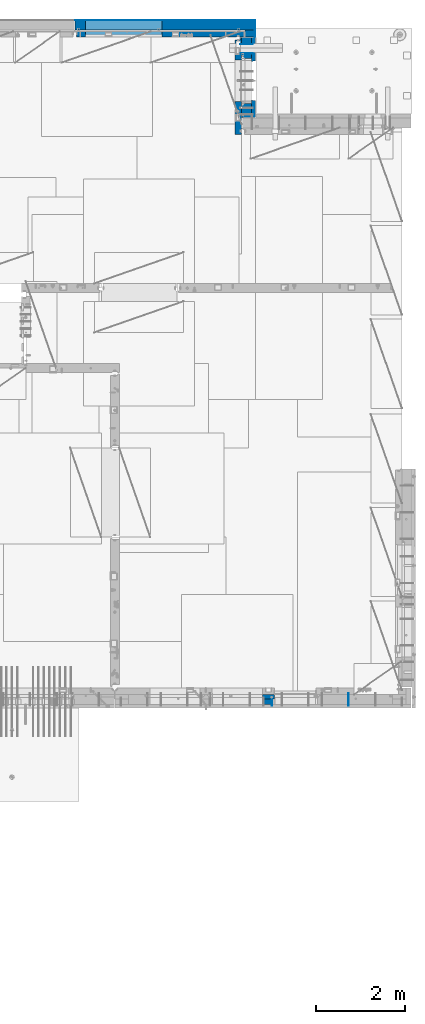
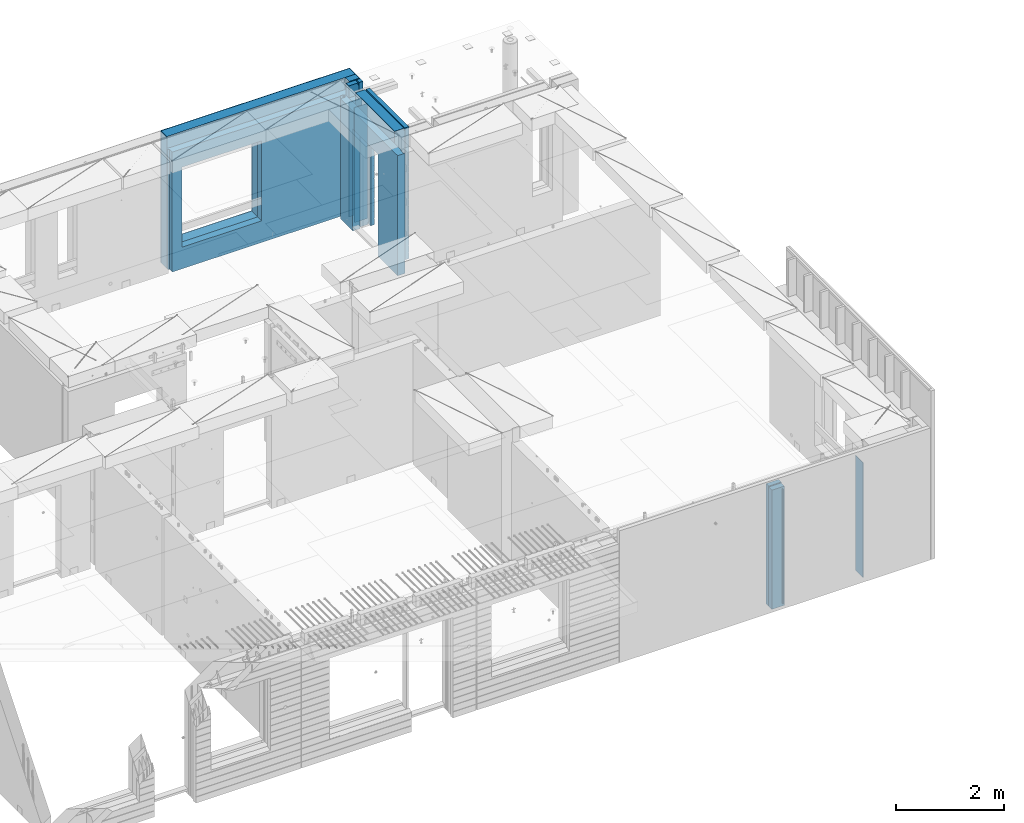
# One storey, part 205 of 309: 14 walls, 3 elements without a shape of their own.
"""IFC2X3 building model written with IfcOpenShell, lengths in millimetres."""

from ifc_helpers import new_model, si_unit, frame, origin_with_axes, place, context, subcontext, project, spatial, faceted_brep, material, type_object, element, aggregate, save


model = new_model("IFC2X3")

# Units and contexts
model_context = context("Model", 3, precision=1e-05, world=origin_with_axes())
body_context = subcontext(model_context, "Body", "Model", "MODEL_VIEW")
ifc_project = project(units=[si_unit("LENGTHUNIT", "METRE", prefix="MILLI"), si_unit("AREAUNIT", "SQUARE_METRE"), si_unit("VOLUMEUNIT", "CUBIC_METRE"), si_unit("MASSUNIT", "GRAM", prefix="KILO"), si_unit("TIMEUNIT", "SECOND"), si_unit("PLANEANGLEUNIT", "RADIAN"), si_unit("SOLIDANGLEUNIT", "STERADIAN"), si_unit("THERMODYNAMICTEMPERATUREUNIT", "DEGREE_CELSIUS"), si_unit("LUMINOUSINTENSITYUNIT", "LUMEN")], contexts=[model_context])

# Site, building, storey
site_placement = place(None, origin_with_axes())
site = spatial("IfcSite", under=ifc_project, at=site_placement, CompositionType="ELEMENT")
building_placement = place(site_placement, origin_with_axes())
building = spatial("IfcBuilding", under=site, at=building_placement, CompositionType="ELEMENT")
storey_placement = place(building_placement, origin_with_axes())
storey = spatial("IfcBuildingStorey", under=building, at=storey_placement, Name="7", CompositionType="ELEMENT", Elevation=0.0)

# Assembly, walls
assembly_1_placement = place(storey_placement, origin_with_axes())
assembly_1 = element("IfcElementAssembly", 1, at=assembly_1_placement, inside=storey, AssemblyPlace="NOTDEFINED", PredefinedType="REINFORCEMENT_UNIT")
ifc_material_1 = material(Name="Undefined")
wall_type_1 = type_object("IfcWallType", PredefinedType="NOTDEFINED")
wall_1_placement = place(assembly_1_placement, frame((33860.0, 7880.0, 101115.0), z_axis=(0.0, 0.0, 1.0), x_axis=(0.0, -1.0, 0.0)))
wall_1 = element("IfcWall", 2, at=wall_1_placement, type_object=wall_type_1, material=ifc_material_1, Name="(PD)", context=body_context, shape_type="Brep", body=[
    faceted_brep([(0.0, 5.0, -1300.0), (0.0, 5.0, 1300.0), (280.0, 5.0, 1300.0), (280.0, 5.0, -1300.0), (0.0, -5.0, 1300.0), (280.0, -5.0, 1300.0), (0.0, -5.0, -1300.0), (280.0, -5.0, -1300.0)], [[[0, 1, 2, 3]], [[1, 4, 5, 2]], [[4, 6, 7, 5]], [[6, 0, 3, 7]], [[5, 7, 3, 2]], [[6, 4, 1, 0]]]),
])
wall_2_placement = place(assembly_1_placement, frame((32144.9998946285, 7780.0, 101115.0), z_axis=(0.0, 0.0, 1.0), x_axis=(0.0, -1.0, 0.0)))
wall_2 = element("IfcWall", 3, at=wall_2_placement, type_object=wall_type_1, material=ifc_material_1, Name="(PD)", context=body_context, shape_type="Brep", body=[
    faceted_brep([(0.0, 5.0, -1300.0), (0.0, 5.0, 1300.0), (180.0, 5.0, 1300.0), (180.0, 5.0, -1300.0), (0.0, -5.0, 1300.0), (180.0, -5.0, 1300.0), (0.0, -5.0, -1300.0), (180.0, -5.0, -1300.0)], [[[0, 1, 2, 3]], [[1, 4, 5, 2]], [[4, 6, 7, 5]], [[6, 0, 3, 7]], [[5, 7, 3, 2]], [[6, 4, 1, 0]]]),
])

assembly_2_placement = place(storey_placement, origin_with_axes())
assembly_2 = element("IfcElementAssembly", 4, at=assembly_2_placement, inside=storey, AssemblyPlace="NOTDEFINED", PredefinedType="REINFORCEMENT_UNIT")
wall_3_placement = place(assembly_2_placement, frame((31429.9951872276, 22245.0, 101115.0), z_axis=(0.0, 0.0, 1.0), x_axis=(1.0, 0.0, 0.0)))
wall_3 = element("IfcWall", 5, at=wall_3_placement, type_object=wall_type_1, material=ifc_material_1, Name="(PD)", context=body_context, shape_type="Brep", body=[
    faceted_brep([(0.0, 5.0, -1300.0), (0.0, 5.0, 1300.0), (280.0, 5.0, 1300.0), (280.0, 5.0, -1300.0), (0.0, -5.0, 1300.0), (280.0, -5.0, 1300.0), (0.0, -5.0, -1300.0), (280.0, -5.0, -1300.0)], [[[0, 1, 2, 3]], [[1, 4, 5, 2]], [[4, 6, 7, 5]], [[6, 0, 3, 7]], [[5, 7, 3, 2]], [[6, 4, 1, 0]]]),
])
wall_4_placement = place(assembly_2_placement, frame((31429.9951872276, 22454.9997558594, 101115.0), z_axis=(0.0, 0.0, 1.0), x_axis=(1.0, 0.0, 0.0)))
wall_4 = element("IfcWall", 6, at=wall_4_placement, type_object=wall_type_1, material=ifc_material_1, Name="(PD)", context=body_context, shape_type="Brep", body=[
    faceted_brep([(0.0, 5.0, -1300.0), (0.0, 5.0, 1300.0), (280.0, 5.0, 1300.0), (280.0, 5.0, -1300.0), (0.0, -5.0, 1300.0), (280.0, -5.0, 1300.0), (0.0, -5.0, -1300.0), (280.0, -5.0, -1300.0)], [[[0, 1, 2, 3]], [[1, 4, 5, 2]], [[4, 6, 7, 5]], [[6, 0, 3, 7]], [[5, 7, 3, 2]], [[6, 4, 1, 0]]]),
])
ifc_material_2 = material(Name="COS5gt")
wall_type_2 = type_object("IfcWallType", PredefinedType="NOTDEFINED")
wall_5_placement = place(assembly_2_placement, frame((31569.9951872276, 22605.0, 101247.5), z_axis=(0.0, 0.0, 1.0), x_axis=(0.0, -1.0, 0.0)))
wall_5 = element("IfcWall", 7, at=wall_5_placement, type_object=wall_type_2, material=ifc_material_2, context=body_context, shape_type="Brep", body=[
    faceted_brep([(355.0, 110.0, 1442.5), (355.0, 109.999999999996, 1222.5), (355.0, -110.0, 1222.5), (355.0, -110.0, 1492.5), (355.0, 90.0, 1492.5), (355.0, 90.0, 1442.5), (255.0, 110.0, 1222.5), (255.0, -110.0, 1222.5), (0.0, 90.0, 1442.5), (0.0, 90.0, 1492.5), (105.0, 90.0, 1492.5), (105.0, 90.0, 1442.5), (0.0, 110.0, 1442.5), (105.0, 110.0, 1442.5), (1800.0, 90.0, -1442.5), (1800.0, 90.0, -1492.5), (1475.00010981862, 90.0, -1492.5), (1475.00010981862, 90.0, -1442.5), (1800.0, 110.0, -1442.5), (1475.00010981862, 110.0, -1442.5), (1800.0, 110.0, 1442.5), (1800.0, 90.0, 1442.5), (1800.0, 90.0, 1492.5), (1800.0, -110.0, 1492.5), (1800.0, -110.0, -1492.5), (1475.00010981862, -110.0, -1492.5), (1475.00010981862, -110.000000000004, 857.5), (1475.00010981862, 110.0, 857.5), (465.000109818619, -110.000000000004, 857.5), (465.000109818619, 110.0, 857.5), (0.0, -110.0, -1492.5), (0.0, 90.0, -1492.5), (465.000109818619, 90.0, -1492.5), (465.000109818619, -110.0, -1492.5), (0.0, 90.0, -1442.5), (465.000109818619, 90.0, -1442.5), (465.000109818619, 110.0, -1442.5), (0.0, 110.0, -1442.5), (0.0, -110.0, 1492.5), (105.0, -110.0, 1492.5), (105.0, -110.0, 1222.5), (105.0, 110.0, 1222.5), (205.0, 110.0, 1222.5), (205.0, -110.0, 1222.5)], [[[0, 1, 2, 3, 4, 5]], [[6, 7, 2, 1]], [[8, 9, 10, 11]], [[12, 8, 11, 13]], [[14, 15, 16, 17]], [[18, 14, 17, 19]], [[20, 21, 22, 23, 24, 15, 14, 18]], [[15, 24, 25, 16]], [[19, 17, 16, 25, 26, 27]], [[27, 26, 28, 29]], [[30, 31, 32, 33]], [[31, 34, 35, 32]], [[29, 28, 33, 32, 35, 36]], [[34, 37, 36, 35]], [[31, 30, 38, 9, 8, 12, 37, 34]], [[9, 38, 39, 10]], [[13, 11, 10, 39, 40, 41]], [[0, 20, 18, 19, 27, 29, 36, 37, 12, 13, 41, 42, 6, 1]], [[21, 20, 0, 5]], [[22, 21, 5, 4]], [[23, 22, 4, 3]], [[43, 40, 39, 38, 30, 33, 28, 26, 25, 24, 23, 3, 2, 7]], [[42, 41, 40, 43, 7, 6]]]),
])

assembly_3_placement = place(storey_placement, origin_with_axes())
assembly_3 = element("IfcElementAssembly", 8, at=assembly_3_placement, inside=storey, AssemblyPlace="NOTDEFINED", PredefinedType="REINFORCEMENT_UNIT")
ifc_material_3 = material()
wall_6_placement = place(assembly_3_placement, frame((31645.0, 22620.0, 101247.5), z_axis=(0.0, 0.0, 1.0), x_axis=(0.0, 1.0, 0.0)))
wall_6 = element("IfcWall", 9, at=wall_6_placement, type_object=wall_type_2, material=ifc_material_3, context=body_context, shape_type="Brep", body=[
    faceted_brep([(0.0, 110.0, -1492.5), (0.0, 110.0, 1492.5), (150.0, 110.0, 1492.5), (150.0, 110.0, -1492.5), (0.0, -110.0, 1492.5), (150.0, -110.0, 1492.5), (0.0, -110.0, -1492.5), (150.0, -110.0, -1492.5)], [[[0, 1, 2, 3]], [[1, 4, 5, 2]], [[4, 6, 7, 5]], [[6, 0, 3, 7]], [[5, 7, 3, 2]], [[6, 4, 1, 0]]]),
])
wall_7_placement = place(assembly_3_placement, frame((27720.0, 22880.0, 101247.5), z_axis=(0.0, 0.0, 1.0), x_axis=(1.0, 0.0, 0.0)))
wall_7 = element("IfcWall", 10, at=wall_7_placement, type_object=wall_type_2, material=ifc_material_3, context=body_context, shape_type="Brep", body=[
    faceted_brep([(0.0, -110.0, -1492.5), (0.0, 110.0, -1492.5), (4035.0, 110.0, -1492.5), (4035.0, -110.0, -1492.5), (0.0, -110.0, 1492.5), (0.0, 110.0, 1492.5), (4035.0, -110.0, 1492.5), (4035.0, 110.0, 1492.5), (234.997879677034, 110.0, -1002.5), (1944.99787967703, 110.0, -1002.5), (1944.99787967703, 110.0, 807.5), (234.997879677034, 110.0, 807.5), (234.997879677034, -110.0, -1002.5), (234.997879677034, -110.0, 807.5), (1944.99787967703, -110.0, 807.5), (1944.99787967703, -110.0, -1002.5)], [[[0, 1, 2, 3]], [[0, 4, 5, 1]], [[5, 4, 6, 7]], [[1, 5, 7, 2], [8, 9, 10, 11]], [[6, 3, 2, 7]], [[4, 0, 3, 6], [12, 13, 14, 15]], [[10, 14, 13, 11]], [[9, 15, 14, 10]], [[8, 12, 15, 9]], [[11, 13, 12, 8]]]),
])

# Wall
ifc_material_4 = material(Name="CONCRETE/C30/37")
wall_type_3 = type_object("IfcWallType", PredefinedType="NOTDEFINED")
wall_8_placement = place(assembly_2_placement, frame((31722.4951872276, 22605.0, 101247.5), z_axis=(0.0, 0.0, 1.0), x_axis=(0.0, -1.0, 0.0)))
wall_8 = element("IfcWall", 11, at=wall_8_placement, type_object=wall_type_3, material=ifc_material_4, context=body_context, shape_type="Brep", body=[
    faceted_brep([(355.0, 42.5, 1492.5), (355.0, 42.4999999227948, 1356.99999988925), (355.0, 32.4999991127006, 1355.00000040044), (355.0, 32.4999992507037, 1344.99999999926), (355.0, 42.4999999595711, 1342.99999994476), (355.0, 42.4999998715975, 1222.5), (355.0, -42.5, 1222.5), (355.0, -42.5, 1492.5), (255.0, 42.4999994355167, 1222.5), (255.0, -42.5, 1222.5), (-3.63797880709171e-12, 32.4999992507037, 1344.99999999926), (-3.63797880709171e-12, 32.4999991127006, 1355.00000040044), (105.0, 32.4999991126897, 1355.00000040043), (105.0, 32.4999992507001, 1344.99999999923), (0.0, 42.5, 1342.99999994476), (105.0, 42.4999996268052, 1342.99999994476), (0.0, 42.5, -1492.5), (0.0, 42.5, -1357.00000005524), (524.998050995091, 42.5, -1357.00000005524), (524.998050995091, 42.5, -1492.5), (0.0, 32.4999992507037, -1355.00000000074), (526.174717749924, 32.4999992507001, -1355.00000000077), (0.0, 32.4999991127006, -1344.99999959956), (526.17471776616, 32.4999991126897, -1344.99999959957), (0.0, 42.5, -1343.00000011075), (524.998050995091, 42.4999994639038, -1343.00000011075), (0.0, 42.5, -1207.00000005524), (524.998050995091, 42.499999489617, -1207.00000005524), (0.0, 32.4999992507037, -1205.00000000074), (526.174717749924, 32.4999992507001, -1205.00000000077), (0.0, 32.4999991127006, -1194.99999959956), (526.17471776616, 32.4999991126897, -1194.99999959957), (0.0, 42.5, -1193.00000011075), (524.998050995091, 42.4999994639038, -1193.00000011075), (0.0, 42.5, -1057.00000005524), (524.998050995091, 42.499999491054, -1057.00000005524), (0.0, 32.4999992507037, -1055.00000000074), (526.174717749924, 32.4999992507001, -1055.00000000077), (0.0, 32.4999991127006, -1044.99999959956), (526.17471776616, 32.4999991126897, -1044.99999959957), (0.0, 42.5, -1043.00000011075), (524.998050995091, 42.4999994639038, -1043.00000011075), (0.0, 42.5, -907.000000055239), (524.998050995091, 42.4999994926584, -907.000000055239), (0.0, 32.4999992507037, -905.000000000742), (526.174717749924, 32.4999992507001, -905.000000000771), (0.0, 32.4999991127006, -894.99999959956), (526.17471776616, 32.4999991126897, -894.999999599575), (0.0, 42.5, -893.000000110755), (524.998050995091, 42.4999994639038, -893.000000110755), (0.0, 42.5, -757.000000055239), (524.998050995091, 42.4999994944665, -757.000000055239), (0.0, 32.4999992507037, -755.000000000742), (526.174717749924, 32.4999992507001, -755.000000000771), (0.0, 32.4999991127006, -744.99999959956), (526.17471776616, 32.4999991126897, -744.999999599575), (0.0, 42.5, -743.000000110755), (524.998050995091, 42.4999994639038, -743.000000110755), (0.0, 42.5, -607.000000055239), (524.998050995091, 42.4999994965183, -607.000000055239), (3.63797880709171e-12, 32.4999992507037, -605.000000000742), (526.174717749924, 32.4999992507001, -605.000000000771), (3.63797880709171e-12, 32.4999991127006, -594.99999959956), (526.17471776616, 32.4999991126897, -594.999999599575), (0.0, 42.5, -593.000000110755), (524.998050995091, 42.4999994639038, -593.000000110755), (0.0, 42.5, -457.000000055239), (524.998050995091, 42.4999994988648, -457.000000055239), (0.0, 32.4999992507037, -455.000000000742), (526.174717749924, 32.4999992507001, -455.000000000771), (0.0, 32.4999991127006, -444.99999959956), (526.17471776616, 32.4999991126897, -444.999999599575), (0.0, 42.5, -443.000000110755), (524.998050995091, 42.4999994639038, -443.000000110755), (0.0, 42.5, -307.000000055239), (524.998050995091, 42.4999995015714, -307.000000055239), (0.0, 32.4999992507037, -305.000000000742), (526.174717749924, 32.4999992507001, -305.000000000771), (0.0, 32.4999991127006, -294.99999959956), (526.17471776616, 32.4999991126897, -294.999999599575), (0.0, 42.5, -293.000000110755), (524.998050995091, 42.4999994639038, -293.000000110755), (0.0, 42.5, -157.000000055239), (524.998050995091, 42.4999995047365, -157.000000055239), (3.63797880709171e-12, 32.4999992507037, -155.000000000742), (526.174717749924, 32.4999992507001, -155.000000000771), (3.63797880709171e-12, 32.4999991127006, -144.99999959956), (526.17471776616, 32.4999991126897, -144.999999599575), (0.0, 42.5, -143.000000110755), (524.998050995091, 42.4999994639038, -143.000000110755), (0.0, 42.5, -7.00000005523907), (524.998050995091, 42.49999950848, -7.00000005523907), (0.0, 32.4999992507037, -5.00000000074215), (526.174717749924, 32.4999992507001, -5.00000000077125), (0.0, 32.4999991127006, 5.0000004004396), (526.17471776616, 32.4999991126897, 5.00000040042505), (0.0, 42.5, 6.99999988924537), (524.998050995091, 42.4999994639038, 6.99999988924537), (0.0, 42.5, 142.999999944761), (524.998050995091, 42.4999995129838, 142.999999944761), (-3.63797880709171e-12, 32.4999992507037, 144.999999999258), (526.174717749924, 32.4999992507001, 144.999999999229), (-3.63797880709171e-12, 32.4999991127006, 155.00000040044), (526.17471776616, 32.4999991126897, 155.000000400425), (0.0, 42.5, 156.999999889245), (524.998050995091, 42.4999994639038, 156.999999889245), (0.0, 42.5, 292.999999944761), (524.998050995091, 42.499999518499, 292.999999944761), (-3.63797880709171e-12, 32.4999992507037, 294.999999999258), (526.174717749924, 32.4999992507001, 294.999999999229), (-3.63797880709171e-12, 32.4999991127006, 305.00000040044), (526.17471776616, 32.4999991126897, 305.000000400425), (0.0, 42.5, 306.999999889245), (524.998050995091, 42.4999994639038, 306.999999889245), (0.0, 42.5, 442.999999944761), (524.998050995091, 42.4999995254038, 442.999999944761), (0.0, 32.4999992507037, 444.999999999258), (526.174717749924, 32.4999992507001, 444.999999999229), (0.0, 32.4999991127006, 455.00000040044), (526.17471776616, 32.4999991126897, 455.000000400425), (0.0, 42.5, 456.999999889245), (524.998050995091, 42.4999994639038, 456.999999889245), (0.0, 42.5, 592.999999944761), (524.998050995091, 42.4999995343132, 592.999999944761), (3.63797880709171e-12, 32.4999992507037, 594.999999999258), (526.174717749924, 32.4999992507001, 594.999999999229), (3.63797880709171e-12, 32.4999991127006, 605.00000040044), (526.17471776616, 32.4999991126897, 605.000000400425), (0.0, 42.5, 606.999999889245), (524.998050995091, 42.4999994639038, 606.999999889245), (0.0, 42.5, 742.999999944761), (524.998050995091, 42.4999995462422, 742.999999944761), (0.0, 32.4999992507037, 744.999999999258), (526.174717749924, 32.4999992507001, 744.999999999229), (0.0, 32.4999991127006, 755.00000040044), (526.17471776616, 32.4999991126897, 755.000000400425), (1800.0, 42.5, -1357.00000005524), (1800.0, 42.5, -1492.5), (1414.99805099509, 42.5, -1492.5), (1414.99805099509, 42.5, -1357.00000005524), (1800.0, 32.4999992507001, -1355.00000000077), (1413.82138424026, 32.4999992507001, -1355.00000000077), (1800.0, 32.4999991126897, -1344.99999959957), (1413.82138422402, 32.4999991126897, -1344.99999959957), (1800.0, 42.5, -1343.00000011075), (1414.99805099509, 42.4999998381209, -1343.00000011075), (1800.0, 42.5, -1207.00000005524), (1414.99805099509, 42.4999998458843, -1207.00000005524), (1800.0, 32.4999992507001, -1205.00000000077), (1413.82138424026, 32.4999992507001, -1205.00000000077), (1800.0, 32.4999991126897, -1194.99999959957), (1413.82138422402, 32.4999991126897, -1194.99999959957), (1800.0, 42.5, -1193.00000011075), (1414.99805099509, 42.4999998381209, -1193.00000011075), (1800.0, 42.5, -1057.00000005524), (1414.99805099509, 42.4999998463172, -1057.00000005524), (1800.0, 32.4999992507001, -1055.00000000077), (1413.82138424026, 32.4999992507001, -1055.00000000077), (1800.0, 32.4999991126897, -1044.99999959957), (1413.82138422402, 32.4999991126897, -1044.99999959957), (1800.0, 42.5, -1043.00000011075), (1414.99805099509, 42.4999998381209, -1043.00000011075), (1800.0, 42.5, -907.000000055239), (1414.99805099509, 42.4999998468011, -907.000000055239), (1800.0, 32.4999992507001, -905.000000000771), (1413.82138424026, 32.4999992507001, -905.000000000771), (1800.0, 32.4999991126897, -894.999999599575), (1413.82138422402, 32.4999991126897, -894.999999599575), (1800.0, 42.5, -893.000000110755), (1414.99805099509, 42.4999998381209, -893.000000110755), (1800.0, 42.5, -757.000000055239), (1414.99805099509, 42.4999998473468, -757.000000055239), (1800.0, 32.4999992507001, -755.000000000771), (1413.82138424026, 32.4999992507001, -755.000000000771), (1800.0, 32.4999991126897, -744.999999599575), (1413.82138422402, 32.4999991126897, -744.999999599575), (1800.0, 42.5, -743.000000110755), (1414.99805099509, 42.4999998381209, -743.000000110755), (1800.0, 42.5, -607.000000055239), (1414.99805099509, 42.4999998479689, -607.000000055239), (1800.0, 32.4999992507001, -605.000000000771), (1413.82138424026, 32.4999992507001, -605.000000000771), (1800.0, 32.4999991126897, -594.999999599575), (1413.82138422402, 32.4999991126897, -594.999999599575), (1800.0, 42.5, -593.000000110755), (1414.99805099509, 42.4999998381209, -593.000000110755), (1800.0, 42.5, -457.000000055239), (1414.99805099509, 42.4999998486746, -457.000000055239), (1800.0, 32.4999992507001, -455.000000000771), (1413.82138424026, 32.4999992507001, -455.000000000771), (1800.0, 32.4999991126897, -444.999999599575), (1413.82138422402, 32.4999991126897, -444.999999599575), (1800.0, 42.5, -443.000000110755), (1414.99805099509, 42.4999998381209, -443.000000110755), (1800.0, 42.5, -307.000000055239), (1414.99805099509, 42.4999998494932, -307.000000055239), (1800.0, 32.4999992507001, -305.000000000771), (1413.82138424026, 32.4999992507001, -305.000000000771), (1800.0, 32.4999991126897, -294.999999599575), (1413.82138422402, 32.4999991126897, -294.999999599575), (1800.0, 42.5, -293.000000110755), (1414.99805099509, 42.4999998381209, -293.000000110755), (1800.0, 42.5, -157.000000055239), (1414.99805099509, 42.49999985045, -157.000000055239), (1800.0, 32.4999992507001, -155.000000000771), (1413.82138424026, 32.4999992507001, -155.000000000771), (1800.0, 32.4999991126897, -144.999999599575), (1413.82138422402, 32.4999991126897, -144.999999599575), (1800.0, 42.5, -143.000000110755), (1414.99805099509, 42.4999998381209, -143.000000110755), (1800.0, 42.5, -7.00000005523907), (1414.99805099509, 42.4999998515814, -7.00000005523907), (1800.0, 32.4999992507001, -5.00000000077125), (1413.82138424026, 32.4999992507001, -5.00000000077125), (1800.0, 32.4999991126897, 5.00000040042505), (1413.82138422402, 32.4999991126897, 5.00000040042505), (1800.0, 42.5, 6.99999988924537), (1414.99805099509, 42.4999998381209, 6.99999988924537), (1800.0, 42.5, 142.999999944761), (1414.99805099509, 42.4999998529383, 142.999999944761), (1800.0, 32.4999992507001, 144.999999999229), (1413.82138424026, 32.4999992507001, 144.999999999229), (1800.0, 32.4999991126897, 155.000000400425), (1413.82138422402, 32.4999991126897, 155.000000400425), (1800.0, 42.5, 156.999999889245), (1414.99805099509, 42.4999998381209, 156.999999889245), (1800.0, 42.5, 292.999999944761), (1414.99805099509, 42.4999998546045, 292.999999944761), (1800.0, 32.4999992507001, 294.999999999229), (1413.82138424026, 32.4999992507001, 294.999999999229), (1800.0, 32.4999991126897, 305.000000400425), (1413.82138422402, 32.4999991126897, 305.000000400425), (1800.0, 42.5, 306.999999889245), (1414.99805099509, 42.4999998381209, 306.999999889245), (1800.0, 42.5, 442.999999944761), (1414.99805099509, 42.4999998566891, 442.999999944761), (1800.0, 32.4999992507001, 444.999999999229), (1413.82138424026, 32.4999992507001, 444.999999999229), (1800.0, 32.4999991126897, 455.000000400425), (1413.82138422402, 32.4999991126897, 455.000000400425), (1800.0, 42.5, 456.999999889245), (1414.99805099509, 42.4999998381209, 456.999999889245), (1800.0, 42.5, 592.999999944761), (1414.99805099509, 42.4999998593812, 592.999999944761), (1800.0, 32.4999992507001, 594.999999999229), (1413.82138424026, 32.4999992507001, 594.999999999229), (1800.0, 32.4999991126897, 605.000000400425), (1413.82138422402, 32.4999991126897, 605.000000400425), (1800.0, 42.5, 606.999999889245), (1414.99805099509, 42.4999998381209, 606.999999889245), (1800.0, 42.5, 742.999999944761), (1414.99805099509, 42.4999998629828, 742.999999944761), (1800.0, 32.4999992507001, 744.999999999229), (1413.82138424026, 32.4999992507001, 744.999999999229), (1800.0, 32.4999991126897, 755.000000400425), (1413.82138422402, 32.4999991126897, 755.000000400425), (1800.0, 42.5, 756.999999889245), (1414.99805099509, 42.4999998381209, 756.999999889245), (0.0, 42.5, 892.999999944761), (0.0, 32.4999992507037, 894.999999999258), (1800.0, 32.4999992507001, 894.999999999229), (1800.0, 42.5, 892.999999944761), (0.0, 32.4999991127006, 905.00000040044), (1800.0, 32.4999991126897, 905.000000400425), (0.0, 42.5, 906.999999889245), (1800.0, 42.5, 906.999999889245), (0.0, 42.5, 1042.99999994476), (1800.0, 42.5, 1042.99999994476), (0.0, 32.4999992507037, 1044.99999999926), (1800.0, 32.4999992507001, 1044.99999999923), (0.0, 32.4999991127006, 1055.00000040044), (1800.0, 32.4999991126897, 1055.00000040043), (0.0, 42.5, 1056.99999988925), (1800.0, 42.5, 1056.99999988925), (0.0, 42.5, 1192.99999994476), (1800.0, 42.5, 1192.99999994476), (0.0, 32.4999992507037, 1194.99999999926), (1800.0, 32.4999992507001, 1194.99999999923), (0.0, 32.4999991127006, 1205.00000040044), (1800.0, 32.4999991126897, 1205.00000040043), (0.0, 42.5, 1206.99999988925), (1800.0, 42.5, 1206.99999988925), (1800.0, 42.5, 1492.5), (1800.0, -42.5, 1492.5), (1800.0, -42.5, -1492.5), (1800.0, 42.5, 1342.99999994476), (1800.0, 32.4999992507001, 1344.99999999923), (1800.0, 32.4999991126897, 1355.00000040043), (1800.0, 42.5, 1356.99999988925), (1404.99638432842, -42.5, -1492.5), (1404.99638432842, -42.5000000000036, 782.5), (1404.99638432842, -42.5000000000036, 787.502857142856), (1414.99805099509, 42.5, 782.5), (535.000109818619, 42.5, 782.5), (1405.00010981862, 42.5, 782.5), (534.999717661758, -42.5000000000036, 787.502857142856), (524.998050995091, 42.5, 782.5), (0.0, 42.5, 756.999999889245), (524.998050995091, 42.4999994639038, 756.999999889245), (534.999717661758, -42.5000000000036, 782.5), (534.999717661754, -42.5, -1492.5), (0.0, -42.5, -1492.5), (0.0, -42.5, 1492.5), (0.0, 42.5, 1492.5), (0.0, 42.5, 1356.99999988925), (105.0, -42.5, 1492.5), (105.0, 42.5, 1492.5), (105.0, 42.499999287309, 1356.99999988925), (105.0, -42.5, 1222.5), (105.0, 42.4999993874699, 1222.5), (205.0, 42.4999994195023, 1222.5), (205.0, -42.5, 1222.5)], [[[0, 1, 2, 3, 4, 5, 6, 7]], [[8, 9, 6, 5]], [[10, 11, 12, 13]], [[14, 10, 13, 15]], [[16, 17, 18, 19]], [[17, 20, 21, 18]], [[20, 22, 23, 21]], [[22, 24, 25, 23]], [[24, 26, 27, 25]], [[26, 28, 29, 27]], [[28, 30, 31, 29]], [[30, 32, 33, 31]], [[32, 34, 35, 33]], [[34, 36, 37, 35]], [[36, 38, 39, 37]], [[38, 40, 41, 39]], [[40, 42, 43, 41]], [[42, 44, 45, 43]], [[44, 46, 47, 45]], [[46, 48, 49, 47]], [[48, 50, 51, 49]], [[50, 52, 53, 51]], [[52, 54, 55, 53]], [[54, 56, 57, 55]], [[56, 58, 59, 57]], [[58, 60, 61, 59]], [[60, 62, 63, 61]], [[62, 64, 65, 63]], [[64, 66, 67, 65]], [[66, 68, 69, 67]], [[68, 70, 71, 69]], [[70, 72, 73, 71]], [[72, 74, 75, 73]], [[74, 76, 77, 75]], [[76, 78, 79, 77]], [[78, 80, 81, 79]], [[80, 82, 83, 81]], [[82, 84, 85, 83]], [[84, 86, 87, 85]], [[86, 88, 89, 87]], [[88, 90, 91, 89]], [[90, 92, 93, 91]], [[92, 94, 95, 93]], [[94, 96, 97, 95]], [[96, 98, 99, 97]], [[98, 100, 101, 99]], [[100, 102, 103, 101]], [[102, 104, 105, 103]], [[104, 106, 107, 105]], [[106, 108, 109, 107]], [[108, 110, 111, 109]], [[110, 112, 113, 111]], [[112, 114, 115, 113]], [[114, 116, 117, 115]], [[116, 118, 119, 117]], [[118, 120, 121, 119]], [[120, 122, 123, 121]], [[122, 124, 125, 123]], [[124, 126, 127, 125]], [[126, 128, 129, 127]], [[128, 130, 131, 129]], [[130, 132, 133, 131]], [[132, 134, 135, 133]], [[136, 137, 138, 139]], [[140, 136, 139, 141]], [[142, 140, 141, 143]], [[144, 142, 143, 145]], [[146, 144, 145, 147]], [[148, 146, 147, 149]], [[150, 148, 149, 151]], [[152, 150, 151, 153]], [[154, 152, 153, 155]], [[156, 154, 155, 157]], [[158, 156, 157, 159]], [[160, 158, 159, 161]], [[162, 160, 161, 163]], [[164, 162, 163, 165]], [[166, 164, 165, 167]], [[168, 166, 167, 169]], [[170, 168, 169, 171]], [[172, 170, 171, 173]], [[174, 172, 173, 175]], [[176, 174, 175, 177]], [[178, 176, 177, 179]], [[180, 178, 179, 181]], [[182, 180, 181, 183]], [[184, 182, 183, 185]], [[186, 184, 185, 187]], [[188, 186, 187, 189]], [[190, 188, 189, 191]], [[192, 190, 191, 193]], [[194, 192, 193, 195]], [[196, 194, 195, 197]], [[198, 196, 197, 199]], [[200, 198, 199, 201]], [[202, 200, 201, 203]], [[204, 202, 203, 205]], [[206, 204, 205, 207]], [[208, 206, 207, 209]], [[210, 208, 209, 211]], [[212, 210, 211, 213]], [[214, 212, 213, 215]], [[216, 214, 215, 217]], [[218, 216, 217, 219]], [[220, 218, 219, 221]], [[222, 220, 221, 223]], [[224, 222, 223, 225]], [[226, 224, 225, 227]], [[228, 226, 227, 229]], [[230, 228, 229, 231]], [[232, 230, 231, 233]], [[234, 232, 233, 235]], [[236, 234, 235, 237]], [[238, 236, 237, 239]], [[240, 238, 239, 241]], [[242, 240, 241, 243]], [[244, 242, 243, 245]], [[246, 244, 245, 247]], [[248, 246, 247, 249]], [[250, 248, 249, 251]], [[252, 250, 251, 253]], [[254, 252, 253, 255]], [[256, 254, 255, 257]], [[258, 259, 260, 261]], [[262, 263, 260, 259]], [[264, 265, 263, 262]], [[265, 264, 266, 267]], [[266, 268, 269, 267]], [[270, 271, 269, 268]], [[272, 273, 271, 270]], [[273, 272, 274, 275]], [[274, 276, 277, 275]], [[278, 279, 277, 276]], [[280, 281, 279, 278]], [[282, 283, 284, 137, 136, 140, 142, 144, 146, 148, 150, 152, 154, 156, 158, 160, 162, 164, 166, 168, 170, 172, 174, 176, 178, 180, 182, 184, 186, 188, 190, 192, 194, 196, 198, 200, 202, 204, 206, 208, 210, 212, 214, 216, 218, 220, 222, 224, 226, 228, 230, 232, 234, 236, 238, 240, 242, 244, 246, 248, 250, 252, 254, 256, 261, 260, 263, 265, 267, 269, 271, 273, 275, 277, 279, 281, 285, 286, 287, 288]], [[137, 284, 289, 138]], [[257, 255, 253, 251, 249, 247, 245, 243, 241, 239, 237, 235, 233, 231, 229, 227, 225, 223, 221, 219, 217, 215, 213, 211, 209, 207, 205, 203, 201, 199, 197, 195, 193, 191, 189, 187, 185, 183, 181, 179, 177, 175, 173, 171, 169, 167, 165, 163, 161, 159, 157, 155, 153, 151, 149, 147, 145, 143, 141, 139, 138, 289, 290, 291, 292]], [[293, 294, 292, 291, 295, 296]], [[297, 258, 261, 256, 257, 292, 294, 293, 296, 298]], [[134, 297, 298, 135]], [[296, 295, 299, 300, 19, 18, 21, 23, 25, 27, 29, 31, 33, 35, 37, 39, 41, 43, 45, 47, 49, 51, 53, 55, 57, 59, 61, 63, 65, 67, 69, 71, 73, 75, 77, 79, 81, 83, 85, 87, 89, 91, 93, 95, 97, 99, 101, 103, 105, 107, 109, 111, 113, 115, 117, 119, 121, 123, 125, 127, 129, 131, 133, 135, 298]], [[301, 16, 19, 300]], [[10, 14, 280, 278, 276, 274, 272, 270, 268, 266, 264, 262, 259, 258, 297, 134, 132, 130, 128, 126, 124, 122, 120, 118, 116, 114, 112, 110, 108, 106, 104, 102, 100, 98, 96, 94, 92, 90, 88, 86, 84, 82, 80, 78, 76, 74, 72, 70, 68, 66, 64, 62, 60, 58, 56, 54, 52, 50, 48, 46, 44, 42, 40, 38, 36, 34, 32, 30, 28, 26, 24, 22, 20, 17, 16, 301, 302, 303, 304, 11]], [[303, 302, 305, 306]], [[304, 303, 306, 307]], [[11, 304, 307, 12]], [[306, 305, 308, 309, 15, 13, 12, 307]], [[4, 285, 281, 280, 14, 15, 309, 310, 8, 5]], [[286, 285, 4, 3]], [[287, 286, 3, 2]], [[288, 287, 2, 1]], [[282, 288, 1, 0]], [[283, 282, 0, 7]], [[311, 308, 305, 302, 301, 300, 299, 295, 291, 290, 289, 284, 283, 7, 6, 9]], [[310, 309, 308, 311, 9, 8]]]),
])

ifc_material_5 = material(Name="CONCRETE/C25/30")
wall_type_4 = type_object("IfcWallType", PredefinedType="NOTDEFINED")
wall_9_placement = place(assembly_2_placement, frame((31384.9951872276, 22620.0, 101112.5), z_axis=(0.0, 0.0, 1.0), x_axis=(0.0, -1.0, 0.0)))
wall_9 = element("IfcWall", 12, at=wall_9_placement, type_object=wall_type_4, material=ifc_material_5, context=body_context, shape_type="Brep", body=[
    faceted_brep([(2190.00481277244, -75.0, 1357.5), (2190.00481277244, -75.0, -1357.5), (2190.00481277244, 75.0, -1357.5), (2190.00481277244, 75.0, 1357.5), (2168.00481277244, 75.0, -1357.5), (2168.00481277244, 75.0, 1357.5), (2155.00481277244, 55.0, -1357.5), (2155.00481277244, 55.0, 1357.5), (2075.00481277244, 55.0, -1357.5), (2075.00481277244, 55.0, 1357.5), (2062.00481277244, 75.0, 1357.5), (2062.00481277244, 75.0, -1357.5), (15.0, 75.0, 1357.5), (15.0, 53.6666666666642, 1357.5), (65.0, 32.0, 1357.5), (65.0, -75.0, 1357.5), (15.0, 75.0, -1357.5), (15.0, 53.6666666666642, -1357.5), (65.0, 32.0, -1357.5), (65.0, -75.0, -1357.5), (1450.00010981862, -75.0, -1357.5), (520.000109818619, -75.0, -1357.5), (520.000109818619, -75.0, 952.5), (1450.00010981862, -75.0, 952.5), (1446.15395597246, 75.0, -1357.5), (1446.15395597247, 75.0, 948.653846153844), (523.846263664771, 75.0, 948.653846153844), (523.846263664771, 75.0, -1357.5)], [[[0, 1, 2, 3]], [[3, 2, 4, 5]], [[5, 4, 6, 7]], [[7, 6, 8, 9]], [[10, 9, 8, 11]], [[12, 13, 14, 15, 0, 3, 5, 7, 9, 10]], [[12, 16, 17, 13]], [[13, 17, 18, 14]], [[14, 18, 19, 15]], [[20, 1, 0, 15, 19, 21, 22, 23]], [[11, 8, 6, 4, 2, 1, 20, 24]], [[16, 12, 10, 11, 24, 25, 26, 27]], [[19, 18, 17, 16, 27, 21]], [[26, 22, 21, 27]], [[25, 23, 22, 26]], [[24, 20, 23, 25]]]),
])

aggregate(assembly_2, [wall_3, wall_4, wall_8, wall_5, wall_9])

wall_10_placement = place(assembly_3_placement, frame((27720.0, 22695.0, 101112.5), z_axis=(0.0, 0.0, 1.0), x_axis=(1.0, 0.0, 0.0)))
wall_10 = element("IfcWall", 13, at=wall_10_placement, type_object=wall_type_4, material=ifc_material_5, context=body_context, shape_type="Brep", body=[
    faceted_brep([(234.997879677034, 75.0, 942.5), (234.997879677034, -75.0, 942.5), (234.997879677034, -75.0, -867.5), (234.997879677034, 75.0, -867.5), (1944.99787967703, -75.0, -867.5), (1944.99787967703, 75.0, -867.5), (1944.99787967703, -75.0, 942.5), (1944.99787967703, 75.0, 942.5), (3815.0, -75.0, 1357.5), (3815.0, -75.0, -1357.5), (3815.0, 75.0, -1357.5), (3815.0, 75.0, 1357.5), (0.0, 75.0, -1357.5), (0.0, 75.0, 1357.5), (0.0, 45.0, -1357.5), (0.0, 45.0, 1357.5), (29.9999989126591, 32.0000004547946, -1357.5), (29.9999989126591, 32.0000004547946, 1357.5), (30.0000016637459, -75.0, -1357.5), (30.0000016637459, -75.0, 1357.5), (3624.99518722756, -75.0, 1357.5), (3637.99518722756, -55.0, 1357.5), (3691.99518722756, -55.0, 1357.5), (3704.99518722756, -75.0, 1357.5), (3704.99518722756, -75.0, -1357.5), (3637.99518722756, -55.0, -1357.5), (3624.99518722756, -75.0, -1357.5), (3691.99518722756, -55.0, -1357.5)], [[[0, 1, 2, 3]], [[3, 2, 4, 5]], [[5, 4, 6, 7]], [[7, 6, 1, 0]], [[8, 9, 10, 11]], [[12, 13, 11, 10], [3, 5, 7, 0]], [[13, 12, 14, 15]], [[15, 14, 16, 17]], [[17, 16, 18, 19]], [[8, 11, 13, 15, 17, 19, 20, 21, 22, 23]], [[9, 8, 23, 24]], [[25, 26, 18, 16, 14, 12, 10, 9, 24, 27]], [[23, 22, 27, 24]], [[21, 25, 27, 22]], [[20, 26, 25, 21]], [[19, 18, 26, 20], [2, 1, 6, 4]]]),
])

wall_type_5 = type_object("IfcWallType", PredefinedType="NOTDEFINED")
wall_11_placement = place(assembly_3_placement, frame((31760.0001313636, 22620.0, 101247.5), z_axis=(0.0, 0.0, 1.0), x_axis=(0.0, 1.0, 0.0)))
wall_11 = element("IfcWall", 14, at=wall_11_placement, type_object=wall_type_5, material=ifc_material_4, context=body_context, shape_type="Brep", body=[
    faceted_brep([(0.0, 5.0, -1492.5), (0.0, 5.0, 1492.5), (370.0, 5.0, 1492.5), (370.0, 5.0, -1492.5), (0.0, -5.0, 1492.5), (370.0, -5.0, 1492.5), (0.0, -5.0, -1492.5), (370.0, -5.0, -1492.5)], [[[0, 1, 2, 3]], [[1, 4, 5, 2]], [[4, 6, 7, 5]], [[6, 0, 3, 7]], [[5, 7, 3, 2]], [[6, 4, 1, 0]]]),
])

wall_12_placement = place(assembly_3_placement, frame((27720.0, 22995.0, 101247.5), z_axis=(0.0, 0.0, 1.0), x_axis=(1.0, 0.0, 0.0)))
wall_12 = element("IfcWall", 15, at=wall_12_placement, type_object=wall_type_5, material=ifc_material_4, context=body_context, shape_type="Brep", body=[
    faceted_brep([(0.0, -5.0, -1492.5), (0.0, 5.0, -1492.5), (4045.0, 5.0, -1492.5), (4045.0, -5.0, -1492.5), (0.0, -5.0, 1492.5), (0.0, 5.0, 1492.5), (4045.0, -5.0, 1492.5), (4045.0, 5.0, 1492.5), (234.997879677034, 5.0, -1002.5), (1944.99787967703, 5.0, -1002.5), (1944.99787967703, 5.0, 807.5), (234.997879677034, 5.0, 807.5), (234.997879677034, -5.0, -1002.5), (234.997879677034, -5.0, 807.5), (1944.99787967703, -5.0, 807.5), (1944.99787967703, -5.0, -1002.5)], [[[0, 1, 2, 3]], [[0, 4, 5, 1]], [[5, 4, 6, 7]], [[1, 5, 7, 2], [8, 9, 10, 11]], [[6, 3, 2, 7]], [[4, 0, 3, 6], [12, 13, 14, 15]], [[10, 14, 13, 11]], [[9, 15, 14, 10]], [[8, 12, 15, 9]], [[11, 13, 12, 8]]]),
])

aggregate(assembly_3, [wall_11, wall_6, wall_12, wall_7, wall_10])

ifc_material_6 = material(Name="CONCRETE/C35/45")
wall_type_6 = type_object("IfcWallType", PredefinedType="NOTDEFINED")
wall_13_placement = place(assembly_1_placement, frame((32195.0000381475, 7800.0, 101112.5), z_axis=(0.0, 0.0, 1.0), x_axis=(-1.0, 3.00000001838171e-08, 0.0)))
wall_13 = element("IfcWall", 16, at=wall_13_placement, type_object=wall_type_6, material=ifc_material_6, context=body_context, shape_type="Brep", body=[
    faceted_brep([(0.0, 50.0, -1357.5), (0.0, 50.0, 1357.5), (270.001908754726, 50.0, 1357.5), (270.001908754726, 50.0, -1357.5), (0.0, -50.0, 1357.5), (270.001908754726, -50.0, 1357.5), (0.0, -50.0, -1357.5), (270.001908754726, -50.0, -1357.5)], [[[0, 1, 2, 3]], [[1, 4, 5, 2]], [[4, 6, 7, 5]], [[6, 0, 3, 7]], [[5, 7, 3, 2]], [[6, 4, 1, 0]]]),
])

ifc_material_7 = material(Name="SPU")
wall_type_7 = type_object("IfcWallType", PredefinedType="NOTDEFINED")
wall_14_placement = place(assembly_1_placement, frame((32195.0000381475, 7690.0, 101102.5), z_axis=(0.0, 0.0, 1.0), x_axis=(-1.0, 3.00000001838171e-08, 0.0)))
wall_14 = element("IfcWall", 17, at=wall_14_placement, type_object=wall_type_7, material=ifc_material_7, context=body_context, shape_type="Brep", body=[
    faceted_brep([(0.0, 60.0, -1347.5), (0.0, 60.0, 1347.5), (270.001908754726, 60.0, 1347.5), (270.001908754726, 60.0, -1347.5), (0.0, -60.0, 1347.5), (270.001908754726, -60.0, 1347.5), (0.0, -60.0, -1347.5), (270.001908754726, -60.0, -1347.5)], [[[0, 1, 2, 3]], [[1, 4, 5, 2]], [[4, 6, 7, 5]], [[6, 0, 3, 7]], [[5, 7, 3, 2]], [[6, 4, 1, 0]]]),
])

aggregate(assembly_1, [wall_1, wall_2, wall_14, wall_13])

save(model, "model.ifc")
